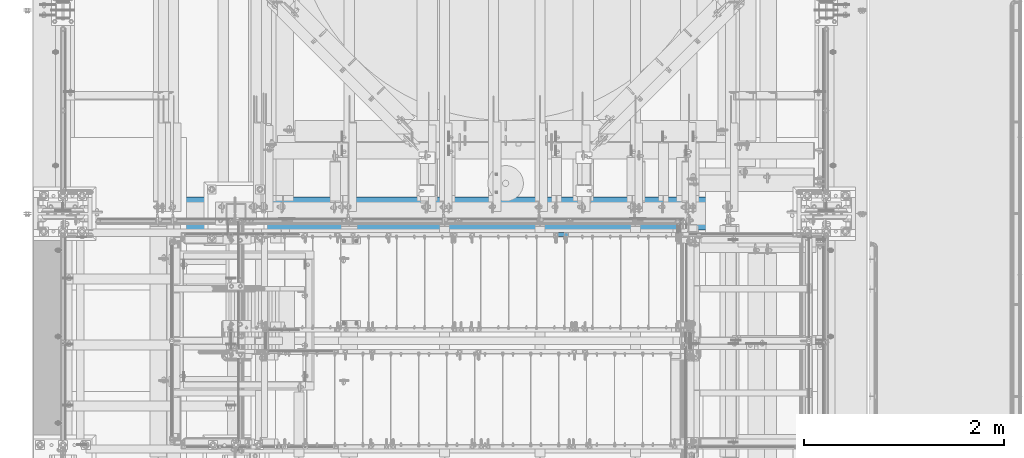
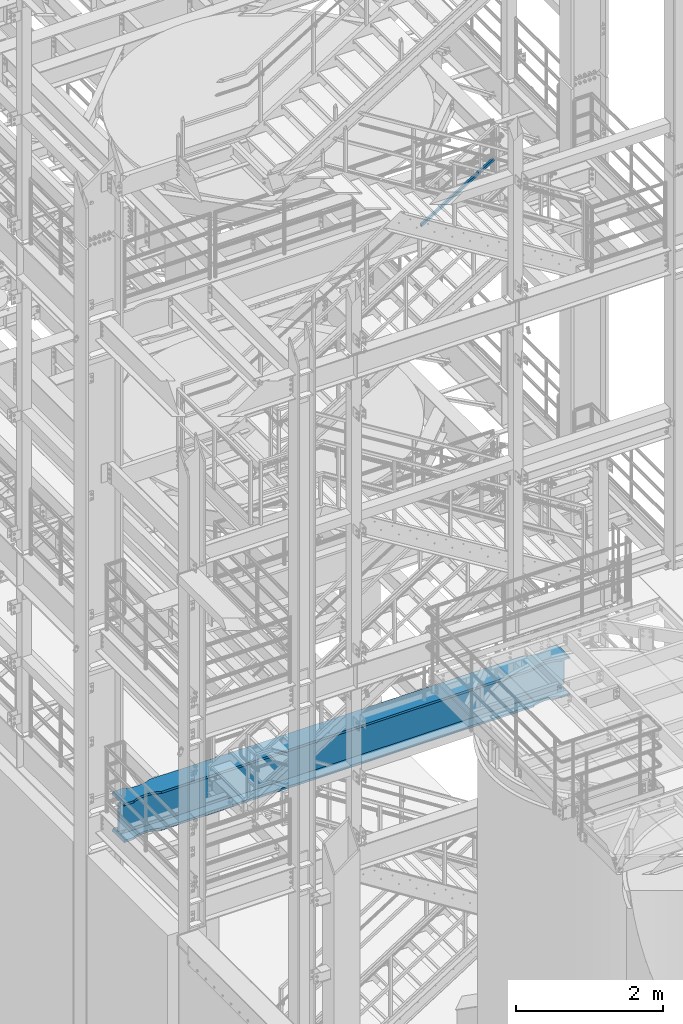
# One storey, part 982 of 1876: 1 beam, 1 member, 2 elements without a shape of their own.
"""IFC2X3 building model written with IfcOpenShell, lengths in millimetres."""

from ifc_helpers import new_model, si_unit, frame, origin_with_axes, place, context, subcontext, project, spatial, faceted_brep, material, type_object, element, aggregate, save


model = new_model("IFC2X3")

# Units and contexts
model_context = context("Model", 3, precision=1e-05, world=origin_with_axes())
body_context = subcontext(model_context, "Body", "Model", "MODEL_VIEW")
ifc_project = project(units=[si_unit("LENGTHUNIT", "METRE", prefix="MILLI"), si_unit("AREAUNIT", "SQUARE_METRE"), si_unit("VOLUMEUNIT", "CUBIC_METRE"), si_unit("MASSUNIT", "GRAM", prefix="KILO"), si_unit("TIMEUNIT", "SECOND"), si_unit("PLANEANGLEUNIT", "RADIAN"), si_unit("SOLIDANGLEUNIT", "STERADIAN"), si_unit("THERMODYNAMICTEMPERATUREUNIT", "DEGREE_CELSIUS"), si_unit("LUMINOUSINTENSITYUNIT", "LUMEN")], contexts=[model_context])

# Site, building, storey
site_placement = place(None, origin_with_axes())
site = spatial("IfcSite", under=ifc_project, at=site_placement, CompositionType="ELEMENT")
building_placement = place(site_placement, origin_with_axes())
building = spatial("IfcBuilding", under=site, at=building_placement, Name="Undefined", CompositionType="ELEMENT")
storey_placement = place(building_placement, origin_with_axes())
storey = spatial("IfcBuildingStorey", under=building, at=storey_placement, Name="Undefined", CompositionType="ELEMENT", Elevation=0.0)

# Assembly, member
assembly_1_placement = place(storey_placement, origin_with_axes())
assembly_1 = element("IfcElementAssembly", 1, at=assembly_1_placement, inside=storey, Name="RAIL", AssemblyPlace="NOTDEFINED", PredefinedType="RIGID_FRAME")
ifc_material_1 = material()
member_type = type_object("IfcMemberType", Name="HSS1-1/2X1-1/2X1/8", PredefinedType="NOTDEFINED")
member_placement = place(assembly_1_placement, frame((4918.07499998656, -4781.55000114554, 13127.9226512767), z_axis=(-0.523953411146183, 0.0, 0.851746924237639), x_axis=(0.851746924237639, 0.0, 0.523953411146184)))
member = element("IfcMember", 2, at=member_placement, type_object=member_type, material=ifc_material_1, Name="RAIL", ObjectType="HSS1-1/2X1-1/2X1/8", context=body_context, shape_type="Brep", body=[
    faceted_brep([(12.6002676416374, 15.8749992829999, -15.8749992830035), (12.6002676416374, -15.8749992829999, -15.8749992830035), (1360.28092592888, -15.8749992829999, -15.8749992833109), (1360.28092592888, 15.8749992829999, -15.8749992833109), (32.1313273721225, -15.8749992829999, 15.874999282998), (1369.26461578157, -15.8749992829999, 15.8749992826924), (32.1313273721225, 15.8749992829999, 15.874999282998), (1369.26461578157, 15.8749992829999, 15.8749992826924), (10.6471616099025, 19.0499992349996, -19.0499992350033), (34.0844334038557, 19.0499992349996, 19.0499992349978), (1370.16298479383, 19.0499992349996, 19.0499992346922), (1359.38255691662, 19.0499992349996, -19.0499992353125), (34.0844334038557, -19.0499992349996, 19.0499992349978), (1370.16298479383, -19.0499992349996, 19.0499992346922), (10.6471616099025, -19.0499992349996, -19.0499992350033), (1359.38255691662, -19.0499992349996, -19.0499992353125)], [[[0, 1, 2, 3]], [[1, 4, 5, 2]], [[4, 6, 7, 5]], [[6, 0, 3, 7]], [[8, 9, 10, 11]], [[9, 12, 13, 10]], [[12, 14, 15, 13]], [[14, 8, 11, 15]], [[13, 15, 11, 10], [5, 7, 3, 2]], [[14, 12, 9, 8], [6, 4, 1, 0]]]),
])
aggregate(assembly_1, [member])

# Assembly, beam
assembly_2_placement = place(storey_placement, origin_with_axes())
assembly_2 = element("IfcElementAssembly", 3, at=assembly_2_placement, inside=storey, Name="BEAM", AssemblyPlace="NOTDEFINED", PredefinedType="RIGID_FRAME")
ifc_material_2 = material(Name="STEEL/A992")
beam_type = type_object("IfcBeamType", Name="W24X192", PredefinedType="NOTDEFINED")
beam_placement = place(assembly_2_placement, frame((0.0, -4572.0, 4806.95), z_axis=(0.0, 0.0, 1.0), x_axis=(1.0, 0.0, 0.0)))
beam = element("IfcBeam", 4, at=beam_placement, type_object=beam_type, material=ifc_material_2, Name="BEAM", ObjectType="W24X192", context=body_context, shape_type="Brep", body=[
    faceted_brep([(301.625, 10.3187500000004, -234.9495), (314.325, -10.3187500000004, -234.9495), (314.325, -10.3187500000004, 234.9495), (301.625, 10.3187500000004, 234.9495), (7318.375, 10.3187500000004, 234.9495), (7305.675, -10.3187500000004, 234.9495), (7305.675, -10.3187500000004, -234.9495), (7318.375, 10.3187500000004, -234.9495), (7318.375, -165.1, 287.3375), (7318.375, -10.3187500000004, 287.3375), (7318.375, 10.3187500000004, 287.3375), (7318.375, 165.1, 287.3375), (7297.29441686758, 165.10000015544, 323.85), (7297.29441686758, -165.10000015544, 323.85), (7162.79999999997, 165.100001147153, 323.85), (7162.79999999997, 165.1, 287.3375), (7106.74278259149, 137.743354635527, 287.3375), (7106.74278259149, 137.743354635527, 323.85), (7106.31195150567, 137.548767822031, 287.3375), (7106.31195150567, 137.548767822031, 323.85), (7105.87030058721, 137.380173875744, 287.3375), (7105.87030058721, 137.380173875744, 323.85), (7105.41939640416, 137.238170811695, 287.3375), (7105.41939640416, 137.238170811695, 323.85), (7104.96083834654, 137.123262325114, 287.3375), (7104.96083834654, 137.123262325114, 323.85), (7027.22388047199, 120.086541102203, 287.3375), (7027.22388047199, 120.086541102203, 323.85), (6946.89999542258, 114.300000048446, 287.3375), (6946.89999542258, 114.300000048446, 323.85), (6866.57611029489, 120.086540015548, 287.3375), (6866.57611029489, 120.086540015548, 323.85), (6787.91106783742, 137.326657821507, 287.3375), (6787.91106783742, 137.326657821507, 323.85), (6731.00000871489, 165.1, 287.3375), (6731.00000871489, 165.100000403941, 323.85), (888.999990590519, 165.1, 287.3375), (888.999990590519, 165.100004421514, 323.85), (832.088931467987, 137.326657821507, 287.3375), (832.088931467987, 137.326657821507, 323.85), (753.423889010533, 120.086540015548, 287.3375), (753.423889010533, 120.086540015548, 323.85), (673.100003882856, 114.300000048446, 287.3375), (673.100003882856, 114.300000048446, 323.85), (592.776118833464, 120.086541102203, 287.3375), (592.776118833464, 120.086541102203, 323.85), (515.039160958935, 137.123262325114, 287.3375), (515.039160958935, 137.123262325114, 323.85), (514.580602901315, 137.238170811695, 287.3375), (514.580602901315, 137.238170811695, 323.85), (514.12969871826, 137.380173875744, 287.3375), (514.12969871826, 137.380173875744, 323.85), (513.688047799806, 137.548767822031, 287.3375), (513.688047799806, 137.548767822031, 323.85), (513.257216713985, 137.743354635527, 287.3375), (513.257216713985, 137.743354635527, 323.85), (457.199999305522, 165.1, 287.3375), (457.199999305522, 165.1, 323.85), (301.625, 165.1, 287.3375), (322.705583132423, 165.1, 323.85), (7162.79999999997, 165.100001147153, -287.3375), (7162.79999999997, 165.1, -323.85), (7106.74278259149, 137.743354635527, -323.85), (7106.74278259149, 137.743354635527, -287.3375), (7106.31195150567, 137.548767822031, -323.85), (7106.31195150567, 137.548767822031, -287.3375), (7105.87030058721, 137.380173875744, -323.85), (7105.87030058721, 137.380173875744, -287.3375), (7105.41939640416, 137.238170811695, -323.85), (7105.41939640416, 137.238170811695, -287.3375), (7104.96083834654, 137.123262325114, -323.85), (7104.96083834654, 137.123262325114, -287.3375), (7027.22388047199, 120.086541102203, -323.85), (7027.22388047199, 120.086541102203, -287.3375), (6946.89999542258, 114.300000048446, -323.85), (6946.89999542258, 114.300000048446, -287.3375), (6866.57611029489, 120.086540015548, -323.85), (6866.57611029489, 120.086540015548, -287.3375), (6787.91106783742, 137.326657821507, -323.85), (6787.91106783742, 137.326657821507, -287.3375), (6731.00000871489, 165.1, -323.85), (6731.00000871489, 165.100000403941, -287.3375), (888.999990590519, 165.1, -323.85), (888.999990590519, 165.100004421514, -287.337500000001), (832.088931467987, 137.326657821507, -323.85), (832.088931467987, 137.326657821507, -287.3375), (753.423889010533, 120.086540015548, -323.85), (753.423889010533, 120.086540015548, -287.3375), (673.100003882856, 114.300000048446, -323.85), (673.100003882856, 114.300000048446, -287.3375), (592.776118833464, 120.086541102203, -323.85), (592.776118833464, 120.086541102203, -287.3375), (515.039160958935, 137.123262325114, -323.85), (515.039160958935, 137.123262325114, -287.3375), (514.580602901315, 137.238170811695, -323.85), (514.580602901315, 137.238170811695, -287.3375), (514.12969871826, 137.380173875744, -323.85), (514.12969871826, 137.380173875744, -287.3375), (513.688047799806, 137.548767822031, -323.85), (513.688047799806, 137.548767822031, -287.3375), (513.257216713985, 137.743354635527, -323.85), (513.257216713985, 137.743354635527, -287.3375), (457.199999305522, 165.1, -323.85), (457.199999305522, 165.1, -287.3375), (301.625, 165.1, -323.85), (322.705590767972, 165.1, -287.3375), (7162.79999999997, -165.100001147153, -287.3375), (7106.74278259149, -137.743354635527, -287.3375), (7106.74278259149, -137.743354635527, -323.85), (7162.79999999997, -165.1, -323.85), (7106.31195150567, -137.548767822031, -287.3375), (7106.31195150567, -137.548767822031, -323.85), (7105.87030058721, -137.380173875744, -287.3375), (7105.87030058721, -137.380173875744, -323.85), (7105.41939640416, -137.238170811695, -287.3375), (7105.41939640416, -137.238170811695, -323.85), (7104.96083834654, -137.123262325114, -287.3375), (7104.96083834654, -137.123262325114, -323.85), (7027.22388047199, -120.086541102203, -287.3375), (7027.22388047199, -120.086541102203, -323.85), (6946.89999542258, -114.300000048446, -287.3375), (6946.89999542258, -114.300000048446, -323.85), (6866.57611029489, -120.086540015548, -287.3375), (6866.57611029489, -120.086540015548, -323.85), (6787.91106783742, -137.326657821507, -287.3375), (6787.91106783742, -137.326657821507, -323.85), (6731.00000871489, -165.100000403941, -287.3375), (6731.00000871489, -165.1, -323.85), (888.999990590519, -165.100004421514, -287.3375), (888.999990590519, -165.1, -323.85), (832.088931467987, -137.326657821507, -287.3375), (832.088931467987, -137.326657821507, -323.85), (753.423889010533, -120.086540015548, -287.3375), (753.423889010533, -120.086540015548, -323.85), (673.100003882856, -114.300000048446, -287.3375), (673.100003882856, -114.300000048446, -323.85), (592.776118833464, -120.086541102203, -287.3375), (592.776118833464, -120.086541102203, -323.85), (515.039160958935, -137.123262325114, -287.3375), (515.039160958935, -137.123262325114, -323.85), (514.580602901315, -137.238170811695, -287.3375), (514.580602901315, -137.238170811695, -323.85), (514.12969871826, -137.380173875744, -287.3375), (514.12969871826, -137.380173875744, -323.85), (513.688047799806, -137.548767822031, -287.3375), (513.688047799806, -137.548767822031, -323.85), (513.257216713985, -137.743354635527, -287.3375), (513.257216713985, -137.743354635527, -323.85), (457.199999305522, -165.1, -287.3375), (457.199999305522, -165.1, -323.85), (322.705590767972, -165.1, -287.3375), (301.625, -165.1, -323.85), (322.934794701563, -10.3187500000004, -286.94050112915), (322.934794701563, 10.3187500000004, -286.94050112915), (322.705590767971, 10.3187500000004, -287.3375), (322.705590767971, -10.3187500000004, -287.3375), (346.976999328614, -10.3187500000004, -286.94050112915), (346.976999328614, 10.3187500000004, -286.94050112915), (420.061565494404, -10.3187500000004, -253.118738544442), (420.061565494404, 10.3187500000004, -253.118738544442), (423.945404365968, -10.3187500000004, -249.819149292641), (423.945404365968, 10.3187500000004, -249.819149292641), (425.572284211328, -10.3187500000004, -244.98957834072), (425.572284211328, 10.3187500000004, -244.98957834072), (424.476487622709, -10.3187500000004, -240.012558806176), (424.476487622709, 10.3187500000004, -240.012558806176), (420.97170190047, -10.3187500000004, -236.312833052547), (420.97170190047, 10.3187500000004, -236.312833052547), (416.061221618592, -10.3187500000004, -234.9495), (416.061221618592, 10.3187500000004, -234.9495), (415.15921904546, -10.3187500000004, 234.949499999999), (415.15921904546, 10.3187500000004, 234.949499999999), (420.069699306212, -10.3187500000004, 236.312833039836), (420.069699306212, 10.3187500000004, 236.312833039836), (423.574485026478, -10.3187500000004, 240.012558762611), (423.574485026478, 10.3187500000004, 240.012558762611), (424.670281642195, -10.3187500000004, 244.989578266865), (424.670281642195, 10.3187500000004, 244.989578266865), (423.043401848172, -10.3187500000004, 249.819149211012), (423.043401848172, 10.3187500000004, 249.819149211012), (419.159563033145, -10.3187500000004, 253.11873849267), (419.159563033145, 10.3187500000004, 253.11873849267), (346.074999237061, -10.3187500000004, 286.94050112915), (346.074999237061, 10.3187500000004, 286.94050112915), (301.625, -10.3187500000004, 286.94050112915), (301.625, 10.3187500000004, 286.94050112915), (301.625, -10.3187500000004, 287.3375), (301.625, 10.3187500000004, 287.3375), (322.705583132423, -165.1, 323.85), (301.625, -165.1, 287.3375), (457.199999305522, -165.1, 287.3375), (457.199999305522, -165.1, 323.85), (513.257216713985, -137.743354635527, 287.3375), (513.257216713985, -137.743354635527, 323.85), (513.688047799806, -137.548767822031, 287.3375), (513.688047799806, -137.548767822031, 323.85), (514.12969871826, -137.380173875744, 287.3375), (514.12969871826, -137.380173875744, 323.85), (514.580602901315, -137.238170811695, 287.3375), (514.580602901315, -137.238170811695, 323.85), (515.039160958935, -137.123262325114, 287.3375), (515.039160958935, -137.123262325114, 323.85), (592.776118833464, -120.086541102203, 287.3375), (592.776118833464, -120.086541102203, 323.85), (673.100003882856, -114.300000048446, 287.3375), (673.100003882856, -114.300000048446, 323.85), (753.423889010533, -120.086540015548, 287.3375), (753.423889010533, -120.086540015548, 323.85), (832.088931467987, -137.326657821507, 287.3375), (832.088931467987, -137.326657821507, 323.85), (888.999990590519, -165.100004421514, 323.85), (888.999990590519, -165.1, 287.3375), (6731.00000871489, -165.1, 287.3375), (6731.00000871489, -165.100000403941, 323.85), (6787.91106783742, -137.326657821507, 287.3375), (6787.91106783742, -137.326657821507, 323.85), (6866.57611029489, -120.086540015548, 287.3375), (6866.57611029489, -120.086540015548, 323.85), (6946.89999542258, -114.300000048446, 287.3375), (6946.89999542258, -114.300000048446, 323.85), (7027.22388047199, -120.086541102203, 287.3375), (7027.22388047199, -120.086541102203, 323.85), (7104.96083834654, -137.123262325114, 287.3375), (7104.96083834654, -137.123262325114, 323.85), (7105.41939640416, -137.238170811695, 287.3375), (7105.41939640416, -137.238170811695, 323.85), (7105.87030058721, -137.380173875744, 287.3375), (7105.87030058721, -137.380173875744, 323.85), (7106.31195150567, -137.548767822031, 287.3375), (7106.31195150567, -137.548767822031, 323.85), (7106.74278259149, -137.743354635527, 287.3375), (7106.74278259149, -137.743354635527, 323.85), (7162.79999999997, -165.100001147153, 323.85), (7162.79999999997, -165.1, 287.3375), (7318.375, -10.3187500000004, 286.94050112915), (7318.375, 10.3187500000004, 286.94050112915), (7273.92500076294, -10.3187500000004, 286.94050112915), (7273.92500076294, 10.3187500000004, 286.94050112915), (7200.84043696685, -10.3187500000004, 253.118738492671), (7200.84043696685, 10.3187500000004, 253.118738492671), (7196.95659815183, -10.3187500000004, 249.819149211013), (7196.95659815183, 10.3187500000004, 249.819149211013), (7195.3297183578, -10.3187500000004, 244.989578266866), (7195.3297183578, 10.3187500000004, 244.989578266866), (7196.42551497352, -10.3187500000004, 240.012558762612), (7196.42551497352, 10.3187500000004, 240.012558762612), (7199.93030069379, -10.3187500000004, 236.312833039837), (7199.93030069379, 10.3187500000004, 236.312833039837), (7204.84078095454, -10.3187500000004, 234.9495), (7204.84078095454, 10.3187500000004, 234.9495), (7203.93877838141, -10.3187500000004, -234.9495), (7203.93877838141, 10.3187500000004, -234.9495), (7199.02829809953, -10.3187500000004, -236.312833052547), (7199.02829809953, 10.3187500000004, -236.312833052547), (7195.52351237729, -10.3187500000004, -240.012558806176), (7195.52351237729, 10.3187500000004, -240.012558806176), (7194.42771578867, -10.3187500000004, -244.98957834072), (7194.42771578867, 10.3187500000004, -244.98957834072), (7196.05459563403, -10.3187500000004, -249.819149292641), (7196.05459563403, 10.3187500000004, -249.819149292641), (7199.93843450559, -10.3187500000004, -253.118738544442), (7199.93843450559, 10.3187500000004, -253.118738544442), (7273.02300067138, -10.3187500000004, -286.94050112915), (7273.02300067138, 10.3187500000004, -286.94050112915), (7297.06520529844, -10.3187500000004, -286.94050112915), (7297.06520529844, 10.3187500000004, -286.94050112915), (7297.29440923203, 10.3187500000004, -287.3375), (7297.29440923203, 165.10000015544, -287.3375), (7318.375, 165.1, -323.85), (7318.375, -165.1, -323.85), (7297.29440923203, -165.10000015544, -287.3375), (7297.29440923203, -10.3187500000004, -287.3375)], [[[0, 1, 2, 3]], [[4, 5, 6, 7]], [[8, 9, 10, 11, 12, 13]], [[14, 15, 16, 17]], [[17, 16, 18, 19]], [[19, 18, 20, 21]], [[21, 20, 22, 23]], [[23, 22, 24, 25]], [[25, 24, 26, 27]], [[27, 26, 28, 29]], [[29, 28, 30, 31]], [[31, 30, 32, 33]], [[33, 32, 34, 35]], [[36, 37, 35, 34]], [[37, 36, 38, 39]], [[39, 38, 40, 41]], [[41, 40, 42, 43]], [[43, 42, 44, 45]], [[45, 44, 46, 47]], [[47, 46, 48, 49]], [[49, 48, 50, 51]], [[51, 50, 52, 53]], [[53, 52, 54, 55]], [[55, 54, 56, 57]], [[57, 56, 58, 59]], [[60, 61, 62, 63]], [[63, 62, 64, 65]], [[65, 64, 66, 67]], [[67, 66, 68, 69]], [[69, 68, 70, 71]], [[71, 70, 72, 73]], [[73, 72, 74, 75]], [[75, 74, 76, 77]], [[77, 76, 78, 79]], [[79, 78, 80, 81]], [[82, 83, 81, 80]], [[83, 82, 84, 85]], [[85, 84, 86, 87]], [[87, 86, 88, 89]], [[89, 88, 90, 91]], [[91, 90, 92, 93]], [[93, 92, 94, 95]], [[95, 94, 96, 97]], [[97, 96, 98, 99]], [[99, 98, 100, 101]], [[101, 100, 102, 103]], [[103, 102, 104, 105]], [[106, 107, 108, 109]], [[110, 111, 108, 107]], [[112, 113, 111, 110]], [[114, 115, 113, 112]], [[116, 117, 115, 114]], [[118, 119, 117, 116]], [[120, 121, 119, 118]], [[122, 123, 121, 120]], [[124, 125, 123, 122]], [[126, 127, 125, 124]], [[128, 129, 127, 126]], [[128, 130, 131, 129]], [[132, 133, 131, 130]], [[134, 135, 133, 132]], [[136, 137, 135, 134]], [[138, 139, 137, 136]], [[140, 141, 139, 138]], [[142, 143, 141, 140]], [[144, 145, 143, 142]], [[146, 147, 145, 144]], [[148, 149, 147, 146]], [[149, 148, 150, 151]], [[152, 153, 154, 105, 104, 151, 150, 155]], [[156, 157, 153, 152]], [[158, 159, 157, 156]], [[160, 161, 159, 158]], [[162, 163, 161, 160]], [[164, 165, 163, 162]], [[166, 167, 165, 164]], [[168, 169, 167, 166]], [[169, 168, 1, 0]], [[170, 171, 3, 2]], [[172, 173, 171, 170]], [[174, 175, 173, 172]], [[176, 177, 175, 174]], [[178, 179, 177, 176]], [[180, 181, 179, 178]], [[182, 183, 181, 180]], [[183, 182, 184, 185]], [[185, 184, 186, 187]], [[188, 59, 58, 187, 186, 189]], [[190, 191, 188, 189]], [[191, 190, 192, 193]], [[193, 192, 194, 195]], [[195, 194, 196, 197]], [[197, 196, 198, 199]], [[199, 198, 200, 201]], [[201, 200, 202, 203]], [[203, 202, 204, 205]], [[205, 204, 206, 207]], [[207, 206, 208, 209]], [[210, 209, 208, 211]], [[210, 211, 212, 213]], [[213, 212, 214, 215]], [[215, 214, 216, 217]], [[217, 216, 218, 219]], [[219, 218, 220, 221]], [[221, 220, 222, 223]], [[223, 222, 224, 225]], [[225, 224, 226, 227]], [[227, 226, 228, 229]], [[229, 228, 230, 231]], [[232, 231, 230, 233]], [[232, 233, 8, 13]], [[14, 17, 19, 21, 23, 25, 27, 29, 31, 33, 35, 37, 39, 41, 43, 45, 47, 49, 51, 53, 55, 57, 59, 188, 191, 193, 195, 197, 199, 201, 203, 205, 207, 209, 210, 213, 215, 217, 219, 221, 223, 225, 227, 229, 231, 232, 13, 12]], [[15, 14, 12, 11]], [[187, 58, 56, 54, 52, 50, 48, 46, 44, 42, 40, 38, 36, 34, 32, 30, 28, 26, 24, 22, 20, 18, 16, 15, 11, 10]], [[234, 235, 10, 9]], [[236, 237, 235, 234]], [[238, 239, 237, 236]], [[240, 241, 239, 238]], [[242, 243, 241, 240]], [[244, 245, 243, 242]], [[246, 247, 245, 244]], [[248, 249, 247, 246]], [[249, 248, 5, 4]], [[250, 251, 7, 6]], [[252, 253, 251, 250]], [[254, 255, 253, 252]], [[256, 257, 255, 254]], [[258, 259, 257, 256]], [[260, 261, 259, 258]], [[262, 263, 261, 260]], [[263, 262, 264, 265]], [[154, 153, 157, 159, 161, 163, 165, 167, 169, 0, 3, 171, 173, 175, 177, 179, 181, 183, 185, 187, 10, 235, 237, 239, 241, 243, 245, 247, 249, 4, 7, 251, 253, 255, 257, 259, 261, 263, 265, 266]], [[60, 63, 65, 67, 69, 71, 73, 75, 77, 79, 81, 83, 85, 87, 89, 91, 93, 95, 97, 99, 101, 103, 105, 154, 266, 267]], [[61, 60, 267, 268]], [[109, 108, 111, 113, 115, 117, 119, 121, 123, 125, 127, 129, 131, 133, 135, 137, 139, 141, 143, 145, 147, 149, 151, 104, 102, 100, 98, 96, 94, 92, 90, 88, 86, 84, 82, 80, 78, 76, 74, 72, 70, 68, 66, 64, 62, 61, 268, 269]], [[106, 109, 269, 270]], [[155, 150, 148, 146, 144, 142, 140, 138, 136, 134, 132, 130, 128, 126, 124, 122, 120, 118, 116, 114, 112, 110, 107, 106, 270, 271]], [[269, 268, 267, 266, 265, 264, 271, 270]], [[168, 166, 164, 162, 160, 158, 156, 152, 155, 271, 264, 262, 260, 258, 256, 254, 252, 250, 6, 5, 248, 246, 244, 242, 240, 238, 236, 234, 9, 186, 184, 182, 180, 178, 176, 174, 172, 170, 2, 1]], [[233, 230, 228, 226, 224, 222, 220, 218, 216, 214, 212, 211, 208, 206, 204, 202, 200, 198, 196, 194, 192, 190, 189, 186, 9, 8]]]),
])
aggregate(assembly_2, [beam])

save(model, "model.ifc")
